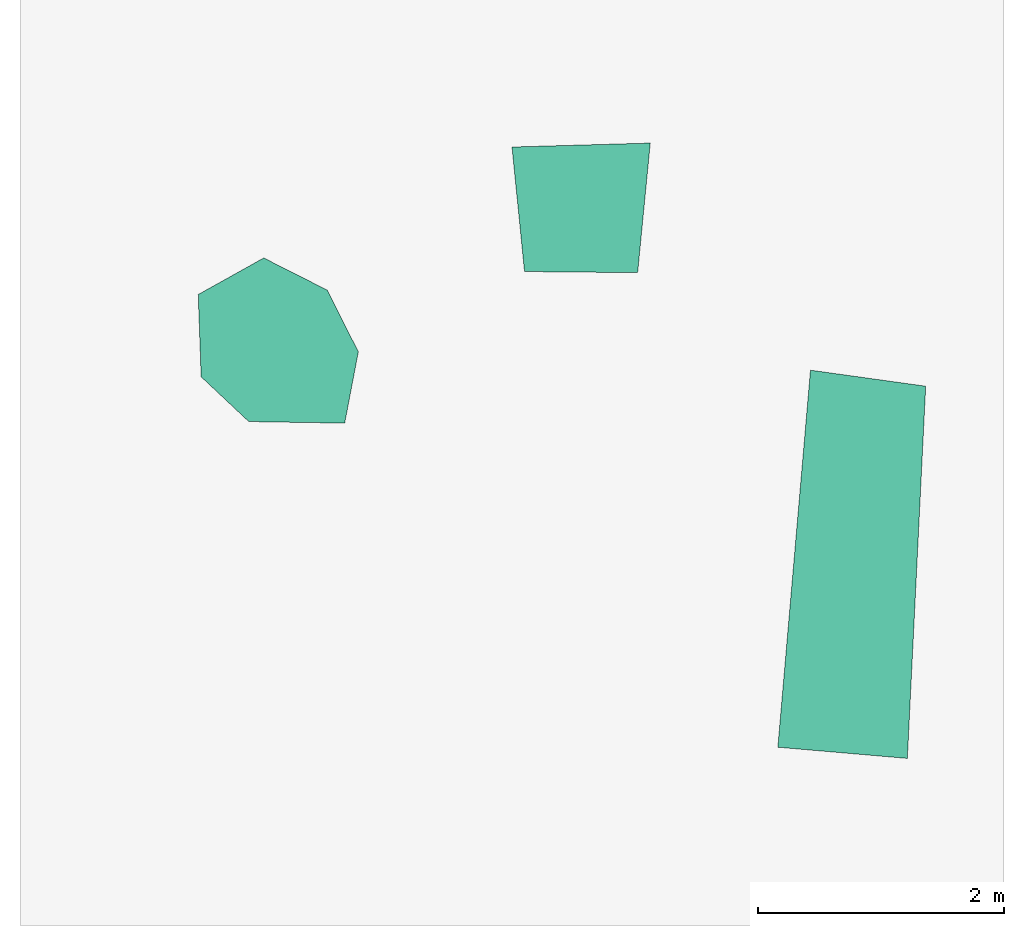
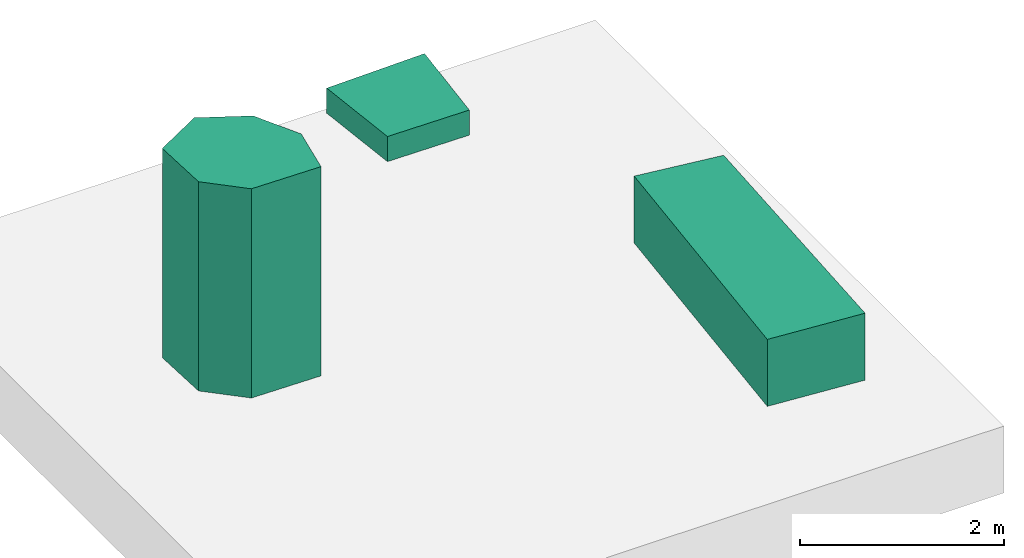
# One storey, part 2 of 2: 2 sanitary terminals, 1 boiler.
"""IFC4X3_ADD2 building model written with IfcOpenShell, lengths in metres."""

from ifc_helpers import new_model, entity, si_unit, converted_unit, frame, origin_with_axes, origin_2d_with_axis, place, context, subcontext, project, spatial, indexed_curve, outline, extrude, material, layer, layer_set, layer_usage, type_object, element, save


model = new_model("IFC4X3_ADD2")

# Units and contexts
model_context = context("Model", 3, precision=1e-05, world=origin_with_axes())
plan_context = context("Plan", 2, precision=1e-05, world=origin_2d_with_axis())
body_context = subcontext(model_context, "Body", "Model", "MODEL_VIEW")
ifc_project = project(units=[si_unit("VOLUMEUNIT", "CUBIC_METRE"), si_unit("LENGTHUNIT", "METRE"), converted_unit("PLANEANGLEUNIT", "degree", entity("IfcReal", 0.0174532925199433), si_unit("PLANEANGLEUNIT", "RADIAN"), dimensions=[0, 0, 0, 0, 0, 0, 0]), si_unit("AREAUNIT", "SQUARE_METRE")], contexts=[model_context, plan_context])

# Site, building, storey
site_placement = place(None, origin_with_axes())
site = spatial("IfcSite", under=ifc_project, at=site_placement)
building_placement = place(site_placement, origin_with_axes())
building = spatial("IfcBuilding", under=site, at=building_placement, Name="Building")
storey_placement = place(building_placement, origin_with_axes())
storey = spatial("IfcBuildingStorey", under=building, at=storey_placement, Name="Storey")

# Boiler
ifc_material = material()
ifc_layer_1 = layer(ifc_material, 2.5)
ifc_layer_set_1 = layer_set([ifc_layer_1])
ifc_layer_usage_1 = layer_usage(ifc_layer_set_1, "AXIS3", "POSITIVE", 0.0)
boiler_type = type_object("IfcBoilerType", Name="Boiler", PredefinedType="WATER", material=ifc_layer_set_1)
boiler_placement = place(storey_placement, frame((1.47266483306885, 4.45980787277222, 0.0), z_axis=(0.0, 0.0, 1.0), x_axis=(1.0, 0.0, 0.0)))
element("IfcBoiler", 1, at=boiler_placement, inside=storey, type_object=boiler_type, material=ifc_layer_usage_1, Name="Boiler", context=body_context, shape_type="SweptSolid", body=[
    extrude(outline(indexed_curve([(0.0, 0.0), (0.387020111083984, -0.363589286804199), (1.16706466674805, -0.376375675201416), (1.27802467346191, 0.203407287597656), (1.02524375915527, 0.705387115478516), (0.509068489074707, 0.966724395751953), (-0.0236625671386719, 0.669580459594727), (0.0, 0.0)])), None, (0.0, 0.0, 1.0), 2.5),
])

# Sanitary terminals
ifc_layer_2 = layer(ifc_material, 0.300000011920929)
ifc_layer_set_2 = layer_set([ifc_layer_2])
ifc_layer_usage_2 = layer_usage(ifc_layer_set_2, "AXIS3", "POSITIVE", 1.29999995231628)
sanitary_terminal_type_1 = type_object("IfcSanitaryTerminalType", PredefinedType="WASHHANDBASIN", material=ifc_layer_set_2)
sanitary_terminal_1_placement = place(storey_placement, frame((4.10177755355835, 5.31577491760254, 0.0), z_axis=(0.0, 0.0, 1.0), x_axis=(1.0, 0.0, 0.0)))
element("IfcSanitaryTerminal", 2, at=sanitary_terminal_1_placement, inside=storey, type_object=sanitary_terminal_type_1, material=ifc_layer_usage_2, Name="WashHand", context=body_context, shape_type="SweptSolid", body=[
    extrude(outline(indexed_curve([(0.0, 0.0), (0.919682025909424, -0.0087440013885498), (1.02242088317871, 1.04473090171814), (-0.10177755355835, 1.01271533966064), (0.0, 0.0)])), frame((0.0, 0.0, 1.29999995231628), z_axis=(0.0, 0.0, 1.0), x_axis=(1.0, 0.0, 0.0)), (0.0, 0.0, 1.0), 0.300000011920929),
])
ifc_layer_3 = layer(ifc_material, 0.800000011920929)
ifc_layer_set_3 = layer_set([ifc_layer_3])
ifc_layer_usage_3 = layer_usage(ifc_layer_set_3, "AXIS3", "POSITIVE", 0.0)
sanitary_terminal_type_2 = type_object("IfcSanitaryTerminalType", Name="Bath", PredefinedType="BATH", material=ifc_layer_set_3)
sanitary_terminal_2_placement = place(storey_placement, frame((6.16124868392944, 1.44859004020691, 0.0), z_axis=(0.0, 0.0, 1.0), x_axis=(1.0, 0.0, 0.0)))
element("IfcSanitaryTerminal", 3, at=sanitary_terminal_2_placement, inside=storey, type_object=sanitary_terminal_type_2, material=ifc_layer_usage_3, Name="Bath", context=body_context, shape_type="SweptSolid", body=[
    extrude(outline(indexed_curve([(0.0, 0.0), (1.0530252456665, -0.0909523963928223), (1.20216178894043, 2.93530678749084), (0.265332221984863, 3.06551194190979), (0.0, 0.0)])), None, (0.0, 0.0, 1.0), 0.800000011920929),
])

save(model, "model.ifc")
